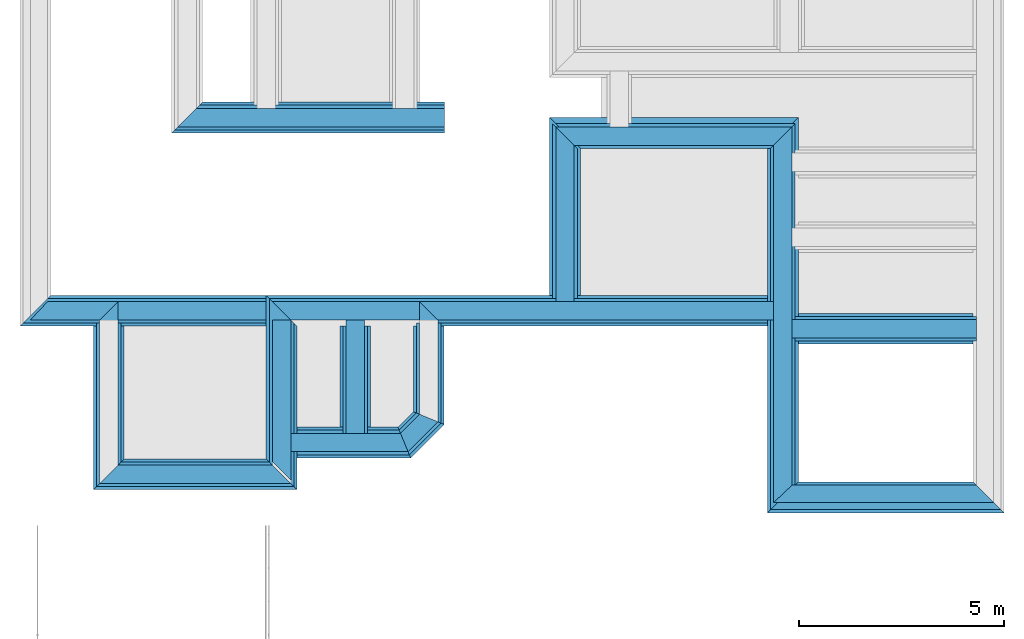
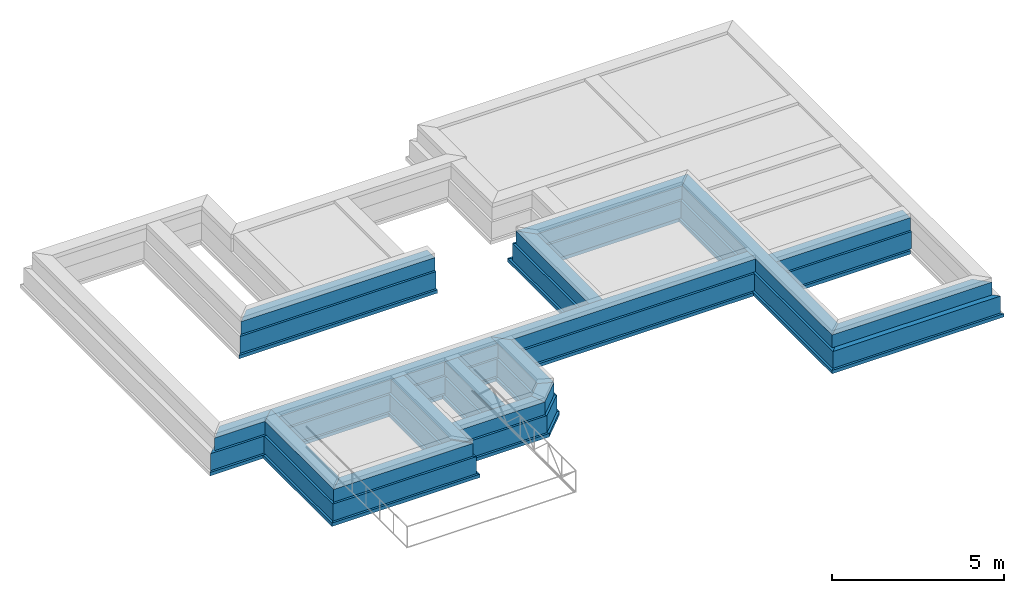
# One storey, part 5 of 7: 46 walls.
"""IFC4X3_ADD2 building model written with IfcOpenShell, lengths in metres."""

from ifc_helpers import new_model, entity, si_unit, converted_unit, frame, origin_with_axes, origin_2d_with_axis, place, context, subcontext, project, spatial, line, indexed_curve, outline, extrude, material, layer, layer_set, layer_usage, type_object, element, save


model = new_model("IFC4X3_ADD2")

# Units and contexts
model_context = context("Model", 3, precision=1e-05, world=origin_with_axes())
plan_context = context("Plan", 2, precision=1e-05, world=origin_2d_with_axis())
body_context = subcontext(model_context, "Body", "Model", "MODEL_VIEW")
ifc_project = project(units=[si_unit("VOLUMEUNIT", "CUBIC_METRE"), si_unit("LENGTHUNIT", "METRE"), converted_unit("PLANEANGLEUNIT", "degree", entity("IfcReal", 0.0174532925199433), si_unit("PLANEANGLEUNIT", "RADIAN"), dimensions=[0, 0, 0, 0, 0, 0, 0]), si_unit("AREAUNIT", "SQUARE_METRE")], contexts=[model_context, plan_context])

# Site, building, storey
site_placement = place(None, origin_with_axes())
site = spatial("IfcSite", under=ifc_project, at=site_placement)
building_placement = place(site_placement, origin_with_axes())
building = spatial("IfcBuilding", under=site, at=building_placement, Name="Building")
storey_placement = place(building_placement, frame((0.0, 0.0, -0.870000004768372), z_axis=(0.0, 0.0, 1.0), x_axis=(1.0, 0.0, 0.0)))
storey = spatial("IfcBuildingStorey", under=building, at=storey_placement, Name="Footing")

# Walls
ifc_material_1 = material(Name="Stone", Category="Structure")
ifc_layer_1 = layer(ifc_material_1, 0.449999988079071)
ifc_layer_set_1 = layer_set([ifc_layer_1])
ifc_layer_usage_1 = layer_usage(ifc_layer_set_1, "AXIS2", "POSITIVE", 0.0)
wall_type_1 = type_object("IfcWallType", Name="RRB_0.45W", PredefinedType="SHEAR", material=ifc_layer_set_1)
wall_1_placement = place(storey_placement, frame((23.7750164771225, 15.3793488442897, 0.719999998807908), z_axis=(0.0, 0.0, 1.0), x_axis=(0.999999999999822, -5.960464477538e-07, 0.0)))
element("IfcWall", 1, at=wall_1_placement, inside=storey, type_object=wall_type_1, material=ifc_layer_usage_1, Name="Wall", context=body_context, shape_type="SweptSolid", body=[
    extrude(outline(indexed_curve([(0.0, 0.0), (-9.81330211661044e-08, 0.449999988079071), (4.48665310620748, 0.449999988079071), (4.48665323122998, 0.0)], segments=[line(1, 2, 3, 4, 1)])), origin_with_axes(), (0.0, 0.0, 1.0), 0.449999988079071),
])
ifc_layer_usage_2 = layer_usage(ifc_layer_set_1, "AXIS2", "POSITIVE", 0.0)
wall_2_placement = place(storey_placement, frame((15.1466770042094, 13.3349130268063, 0.719999998807908), z_axis=(0.0, 0.0, 1.0), x_axis=(3.13916473260163e-07, 0.999999999999951, 0.0)))
element("IfcWall", 2, at=wall_2_placement, inside=storey, type_object=wall_type_1, material=ifc_layer_usage_2, Name="Wall", context=body_context, shape_type="SweptSolid", body=[
    extrude(outline(indexed_curve([(0.0, 0.0), (0.186396055761703, 0.449999988079071), (2.93110990416569, 0.449999988079071), (2.48110978576698, 0.0)], segments=[line(1, 2, 3, 4, 1)])), origin_with_axes(), (0.0, 0.0, 1.0), 0.449999988079071),
])
ifc_layer_usage_3 = layer_usage(ifc_layer_set_1, "AXIS2", "POSITIVE", 0.0)
wall_3_placement = place(storey_placement, frame((15.0466774778525, 15.8160228729249, 0.719999998807908), z_axis=(0.0, 0.0, 1.0), x_axis=(0.999999999999822, -5.960464477538e-07, 0.0)))
element("IfcWall", 3, at=wall_3_placement, inside=storey, type_object=wall_type_1, material=ifc_layer_usage_3, Name="Wall", context=body_context, shape_type="SweptSolid", body=[
    extrude(outline(indexed_curve([(0.0, 0.0), (-0.450000103371296, 0.449999988079071), (8.2783390779459, 0.449999988079071), (8.27833917616148, 0.0)], segments=[line(1, 2, 3, 4, 1)])), origin_with_axes(), (0.0, 0.0, 1.0), 0.449999988079071),
])
ifc_layer_usage_4 = layer_usage(ifc_layer_set_1, "AXIS2", "POSITIVE", 0.0)
wall_4_placement = place(storey_placement, frame((7.35359666377311, 12.2860256676357, 0.719999998807908), z_axis=(0.0, 0.0, 1.0), x_axis=(3.13916473260163e-07, 0.999999999999951, 0.0)))
element("IfcWall", 4, at=wall_4_placement, inside=storey, type_object=wall_type_1, material=ifc_layer_usage_4, Name="Wall", context=body_context, shape_type="SweptSolid", body=[
    extrude(outline(indexed_curve([(0.0, 0.0), (-0.449999961074437, 0.449999988079071), (3.52999582324251, 0.449999988079071), (3.97999606087995, 0.0)], segments=[line(1, 2, 3, 4, 1)])), origin_with_axes(), (0.0, 0.0, 1.0), 0.449999988079071),
])
ifc_layer_usage_5 = layer_usage(ifc_layer_set_1, "AXIS2", "POSITIVE", 0.0)
wall_5_placement = place(storey_placement, frame((23.7750149557985, 11.3693475723266, 0.719999998807908), z_axis=(0.0, 0.0, 1.0), x_axis=(3.13916473260163e-07, 0.999999999999951, 0.0)))
element("IfcWall", 5, at=wall_5_placement, inside=storey, type_object=wall_type_1, material=ifc_layer_usage_5, Name="Wall", context=body_context, shape_type="SweptSolid", body=[
    extrude(outline(indexed_curve([(0.42500000074508, 0.0), (1.47028964871403e-07, 0.449999988079071), (8.70354421117045, 0.449999988079071), (9.15354410546069, 0.0)], segments=[line(1, 2, 3, 4, 1)])), origin_with_axes(), (0.0, 0.0, 1.0), 0.449999988079071),
])
ifc_layer_usage_6 = layer_usage(ifc_layer_set_1, "AXIS2", "POSITIVE", 0.0)
wall_6_placement = place(storey_placement, frame((9.25813584427108, 20.5243873596191, 0.719999998807908), z_axis=(0.0, 0.0, 1.0), x_axis=(0.999999999999822, -5.960464477538e-07, 0.0)))
element("IfcWall", 6, at=wall_6_placement, inside=storey, type_object=wall_type_1, material=ifc_layer_usage_6, Name="Wall", context=body_context, shape_type="SweptSolid", body=[
    extrude(outline(indexed_curve([(-0.449999988079087, 0.0), (-1.22067763074548e-07, 0.449999988079071), (6.05208381845608, 0.449999988079071), (6.05208381845608, 0.0)], segments=[line(1, 2, 3, 4, 1)])), origin_with_axes(), (0.0, 0.0, 1.0), 0.449999988079071),
])
ifc_layer_usage_7 = layer_usage(ifc_layer_set_1, "AXIS2", "POSITIVE", 0.0)
wall_7_placement = place(storey_placement, frame((11.5629977944495, 12.3610239028931, 0.719999998807908), z_axis=(0.0, 0.0, 1.0), x_axis=(3.13916473260163e-07, 0.999999999999951, 0.0)))
element("IfcWall", 7, at=wall_7_placement, inside=storey, type_object=wall_type_1, material=ifc_layer_usage_7, Name="Wall", context=body_context, shape_type="SweptSolid", body=[
    extrude(outline(indexed_curve([(-0.449999988079072, 0.0), (2.68782058983727e-08, 0.449999988079071), (3.45499654674015, 0.449999988079071), (3.454996452804, 0.0)], segments=[line(1, 2, 3, 4, 1)])), origin_with_axes(), (0.0, 0.0, 1.0), 0.449999988079071),
])
ifc_layer_usage_8 = layer_usage(ifc_layer_set_1, "AXIS2", "POSITIVE", 0.0)
wall_8_placement = place(storey_placement, frame((14.4189835934303, 12.6072198349405, 0.719999998807908), z_axis=(0.0, 0.0, 1.0), x_axis=(0.707106840791191, 0.707106721581899, 0.0)))
element("IfcWall", 8, at=wall_8_placement, inside=storey, type_object=wall_type_1, material=ifc_layer_usage_8, Name="Wall", context=body_context, shape_type="SweptSolid", body=[
    extrude(outline(indexed_curve([(0.0, 0.0), (0.186396239135942, 0.449999988079071), (0.842717773351463, 0.449999988079071), (1.02911380402565, 0.0)], segments=[line(1, 2, 3, 4, 1)])), origin_with_axes(), (0.0, 0.0, 1.0), 0.449999988079071),
])
ifc_layer_usage_9 = layer_usage(ifc_layer_set_1, "AXIS2", "POSITIVE", 0.0)
wall_9_placement = place(storey_placement, frame((13.3589563840624, 12.6072204919225, 0.719999998807908), z_axis=(0.0, 0.0, 1.0), x_axis=(3.13916473260163e-07, 0.999999999999951, 0.0)))
element("IfcWall", 9, at=wall_9_placement, inside=storey, type_object=wall_type_1, material=ifc_layer_usage_9, Name="Wall", context=body_context, shape_type="SweptSolid", body=[
    extrude(outline(indexed_curve([(0.449999988079092, 0.0), (0.450000125309711, 0.449999988079071), (3.20880352988753, 0.449999988079071), (3.20880339956792, 0.0)], segments=[line(1, 2, 3, 4, 1)])), origin_with_axes(), (0.0, 0.0, 1.0), 0.449999988079071),
])
ifc_layer_usage_10 = layer_usage(ifc_layer_set_1, "AXIS2", "POSITIVE", 0.0)
wall_10_placement = place(storey_placement, frame((15.1466780013493, 16.2660184840428, 0.719999998807908), z_axis=(0.0, 0.0, 1.0), x_axis=(-0.999999999999924, 3.89414367418765e-07, 0.0)))
element("IfcWall", 10, at=wall_10_placement, inside=storey, type_object=wall_type_1, material=ifc_layer_usage_10, Name="Wall", context=body_context, shape_type="SweptSolid", body=[
    extrude(outline(indexed_curve([(0.449999988079071, 0.0), (0.449999965929192, 0.449999988079071), (7.79307999653564, 0.449999988079071), (7.79308002299699, 0.0)], segments=[line(1, 2, 3, 4, 1)])), origin_with_axes(), (0.0, 0.0, 1.0), 0.449999988079071),
])
ifc_layer_usage_11 = layer_usage(ifc_layer_set_1, "AXIS2", "POSITIVE", 0.0)
wall_11_placement = place(storey_placement, frame((11.5629977696537, 12.2860240936279, 0.719999998807908), z_axis=(0.0, 0.0, 1.0), x_axis=(-0.999999999999924, 3.89414367418765e-07, 0.0)))
element("IfcWall", 11, at=wall_11_placement, inside=storey, type_object=wall_type_1, material=ifc_layer_usage_11, Name="Wall", context=body_context, shape_type="SweptSolid", body=[
    extrude(outline(indexed_curve([(0.449999988079072, 0.0), (-2.6461350745525e-08, 0.449999988079071), (4.65940106875073, 0.449999988079071), (4.20940110713301, 0.0)], segments=[line(1, 2, 3, 4, 1)])), origin_with_axes(), (0.0, 0.0, 1.0), 0.449999988079071),
])
ifc_layer_usage_12 = layer_usage(ifc_layer_set_1, "AXIS2", "POSITIVE", 0.0)
wall_12_placement = place(storey_placement, frame((18.466680573821, 15.8160208088996, 0.719999998807908), z_axis=(0.0, 0.0, 1.0), x_axis=(3.13916473260163e-07, 0.999999999999951, 0.0)))
element("IfcWall", 12, at=wall_12_placement, inside=storey, type_object=wall_type_1, material=ifc_layer_usage_12, Name="Wall", context=body_context, shape_type="SweptSolid", body=[
    extrude(outline(indexed_curve([(0.44999998807909, 0.0), (0.450000118398703, 0.449999988079071), (4.70687373541192, 0.449999988079071), (4.256873653544, 0.0)], segments=[line(1, 2, 3, 4, 1)])), origin_with_axes(), (0.0, 0.0, 1.0), 0.449999988079071),
])
ifc_layer_usage_13 = layer_usage(ifc_layer_set_1, "AXIS2", "POSITIVE", 0.0)
wall_13_placement = place(storey_placement, frame((11.5629978758452, 12.6072216033935, 0.719999998807908), z_axis=(0.0, 0.0, 1.0), x_axis=(0.999999999999822, -5.960464477538e-07, 0.0)))
element("IfcWall", 13, at=wall_13_placement, inside=storey, type_object=wall_type_1, material=ifc_layer_usage_13, Name="Wall", context=body_context, shape_type="SweptSolid", body=[
    extrude(outline(indexed_curve([(0.0, 0.0), (-1.19445784433059e-07, 0.449999988079071), (2.66958956740739, 0.449999988079071), (2.85598578373842, 0.0)], segments=[line(1, 2, 3, 4, 1)])), origin_with_axes(), (0.0, 0.0, 1.0), 0.449999988079071),
])
ifc_layer_usage_14 = layer_usage(ifc_layer_set_1, "AXIS2", "POSITIVE", 0.0)
wall_14_placement = place(storey_placement, frame((7.35359797835293, 16.2660217285155, 0.719999998807908), z_axis=(0.0, 0.0, 1.0), x_axis=(-0.999999999999924, 3.89414367418765e-07, 0.0)))
element("IfcWall", 14, at=wall_14_placement, inside=storey, type_object=wall_type_1, material=ifc_layer_usage_14, Name="Wall", context=body_context, shape_type="SweptSolid", body=[
    extrude(outline(indexed_curve([(0.0, 0.0), (0.449999961617721, 0.449999988079071), (2.13955890890689, 0.449999988079071), (1.714558939226, 0.0)], segments=[line(1, 2, 3, 4, 1)])), origin_with_axes(), (0.0, 0.0, 1.0), 0.449999988079071),
])
ifc_layer_usage_15 = layer_usage(ifc_layer_set_1, "AXIS2", "POSITIVE", 0.0)
wall_15_placement = place(storey_placement, frame((18.4666819764865, 20.0728944624433, 0.719999998807908), z_axis=(0.0, 0.0, 1.0), x_axis=(0.999999999999822, -5.960464477538e-07, 0.0)))
element("IfcWall", 15, at=wall_15_placement, inside=storey, type_object=wall_type_1, material=ifc_layer_usage_15, Name="Wall", context=body_context, shape_type="SweptSolid", body=[
    extrude(outline(indexed_curve([(0.0, 0.0), (-0.450000108145878, 0.449999988079071), (5.30833617205419, 0.449999988079071), (4.85833628210813, 0.0)], segments=[line(1, 2, 3, 4, 1)])), origin_with_axes(), (0.0, 0.0, 1.0), 0.449999988079071),
])
ifc_material_2 = material(Name="Plaster", Category="Finishes")
ifc_layer_2 = layer(ifc_material_2, 0.00999999977648258)
ifc_layer_3 = layer(ifc_material_1, 0.405000001192093)
ifc_layer_4 = layer(ifc_material_2, 0.00999999977648258)
ifc_layer_set_2 = layer_set([ifc_layer_2, ifc_layer_3, ifc_layer_4])
ifc_layer_usage_16 = layer_usage(ifc_layer_set_2, "AXIS2", "POSITIVE", 0.0)
wall_type_2 = type_object("IfcWallType", Name="RRB_0.425W", PredefinedType="SHEAR", material=ifc_layer_set_2)
wall_16_placement = place(storey_placement, frame((23.7750149621858, 11.3693475723266, 0.719999998807908), z_axis=(0.0, 0.0, 1.0), x_axis=(0.999999999999822, -5.960464477538e-07, 0.0)))
element("IfcWall", 16, at=wall_16_placement, inside=storey, type_object=wall_type_2, material=ifc_layer_usage_16, Name="Wall", context=body_context, shape_type="SweptSolid", body=[
    extrude(outline(indexed_curve([(-0.449999988079081, 0.0), (-9.26811892745667e-08, 0.425000000745058), (4.48665335278053, 0.425000000745058), (4.91165347159026, 0.0)], segments=[line(1, 2, 3, 4, 1)])), origin_with_axes(), (0.0, 0.0, 1.0), 0.449999988079071),
])
ifc_material_3 = material(Name="Wall")
ifc_layer_5 = layer(ifc_material_3, 0.600000023841858, Name="concrete")
ifc_layer_set_3 = layer_set([ifc_layer_5], Name="concrete")
ifc_layer_usage_17 = layer_usage(ifc_layer_set_3, "AXIS2", "POSITIVE", 0.0)
wall_type_3 = type_object("IfcWallType", Name="RRB_0.6W", PredefinedType="SHEAR", material=ifc_layer_set_3)
wall_17_placement = place(storey_placement, frame((14.4500515221254, 12.5322200975236, 0.120000004768372), z_axis=(0.0, 0.0, 1.0), x_axis=(0.707106840791191, 0.707106721581899, 0.0)))
element("IfcWall", 17, at=wall_17_placement, inside=storey, type_object=wall_type_3, material=ifc_layer_usage_17, Name="Wall", context=body_context, shape_type="SweptSolid", body=[
    extrude(outline(indexed_curve([(0.0, 0.0), (0.248528335537855, 0.600000023841858), (0.842714835397712, 0.600000023841858), (1.09124289229101, 0.0)], segments=[line(1, 2, 3, 4, 1)])), origin_with_axes(), (0.0, 0.0, 1.0), 0.600000023841858),
])
ifc_layer_usage_18 = layer_usage(ifc_layer_set_3, "AXIS2", "POSITIVE", 0.0)
wall_18_placement = place(storey_placement, frame((11.6379976037146, 12.3610239320991, 0.120000004768372), z_axis=(0.0, 0.0, 1.0), x_axis=(-0.999999999999924, 3.89414367418765e-07, 0.0)))
element("IfcWall", 18, at=wall_18_placement, inside=storey, type_object=wall_type_3, material=ifc_layer_usage_18, Name="Wall", context=body_context, shape_type="SweptSolid", body=[
    extrude(outline(indexed_curve([(0.600000023841859, 0.0), (-3.37259327238358e-08, 0.600000023841858), (4.80940064221081, 0.600000023841858), (4.20940065383951, 0.0)], segments=[line(1, 2, 3, 4, 1)])), origin_with_axes(), (0.0, 0.0, 1.0), 0.600000023841858),
])
ifc_layer_usage_19 = layer_usage(ifc_layer_set_3, "AXIS2", "POSITIVE", 0.0)
wall_19_placement = place(storey_placement, frame((18.5416794058681, 15.7410208639421, 0.120000004768372), z_axis=(0.0, 0.0, 1.0), x_axis=(3.13916473260163e-07, 0.999999999999951, 0.0)))
element("IfcWall", 19, at=wall_19_placement, inside=storey, type_object=wall_type_3, material=ifc_layer_usage_19, Name="Wall", context=body_context, shape_type="SweptSolid", body=[
    extrude(outline(indexed_curve([(0.600000023841883, 0.0), (0.600000196322957, 0.600000023841858), (4.85687366928037, 0.600000023841858), (4.25687346879169, 0.0)], segments=[line(1, 2, 3, 4, 1)])), origin_with_axes(), (0.0, 0.0, 1.0), 0.600000023841858),
])
ifc_layer_usage_20 = layer_usage(ifc_layer_set_3, "AXIS2", "POSITIVE", 0.0)
wall_20_placement = place(storey_placement, frame((23.8500150770871, 15.3043489903219, 0.120000004768372), z_axis=(0.0, 0.0, 1.0), x_axis=(0.999999999999822, -5.960464477538e-07, 0.0)))
element("IfcWall", 20, at=wall_20_placement, inside=storey, type_object=wall_type_3, material=ifc_layer_usage_20, Name="Wall", context=body_context, shape_type="SweptSolid", body=[
    extrude(outline(indexed_curve([(0.0, 0.0), (-1.64834769827048e-07, 0.600000023841858), (4.41165560377788, 0.600000023841858), (4.41165577052876, 0.0)], segments=[line(1, 2, 3, 4, 1)])), origin_with_axes(), (0.0, 0.0, 1.0), 0.600000023841858),
])
ifc_layer_usage_21 = layer_usage(ifc_layer_set_3, "AXIS2", "POSITIVE", 0.0)
wall_21_placement = place(storey_placement, frame((13.4339570999146, 12.457221031189, 0.120000004768372), z_axis=(0.0, 0.0, 1.0), x_axis=(3.13916473260163e-07, 0.999999999999951, 0.0)))
element("IfcWall", 21, at=wall_21_placement, inside=storey, type_object=wall_type_3, material=ifc_layer_usage_21, Name="Wall", context=body_context, shape_type="SweptSolid", body=[
    extrude(outline(indexed_curve([(0.600000023841886, 0.0), (0.600000207250802, 0.600000023841858), (3.20880245678658, 0.600000023841858), (3.20880245678658, 0.0)], segments=[line(1, 2, 3, 4, 1)])), origin_with_axes(), (0.0, 0.0, 1.0), 0.600000023841858),
])
ifc_layer_usage_22 = layer_usage(ifc_layer_set_3, "AXIS2", "POSITIVE", 0.0)
wall_22_placement = place(storey_placement, frame((11.6379987314599, 15.7410250157116, 0.120000004768372), z_axis=(0.0, 0.0, 1.0), x_axis=(0.999999999999822, -5.960464477538e-07, 0.0)))
element("IfcWall", 22, at=wall_22_placement, inside=storey, type_object=wall_type_3, material=ifc_layer_usage_22, Name="Wall", context=body_context, shape_type="SweptSolid", body=[
    extrude(outline(indexed_curve([(0.0, 0.0), (-0.600000181284445, 0.600000023841858), (11.6120162987777, 0.600000023841858), (11.6120164636125, 0.0)], segments=[line(1, 2, 3, 4, 1)])), origin_with_axes(), (0.0, 0.0, 1.0), 0.600000023841858),
])
ifc_layer_usage_23 = layer_usage(ifc_layer_set_3, "AXIS2", "POSITIVE", 0.0)
wall_23_placement = place(storey_placement, frame((11.6379989301293, 16.3410187059637, 0.120000004768372), z_axis=(0.0, 0.0, 1.0), x_axis=(-0.999999999999924, 3.89414367418765e-07, 0.0)))
element("IfcWall", 23, at=wall_23_placement, inside=storey, type_object=wall_type_3, material=ifc_layer_usage_23, Name="Wall", context=body_context, shape_type="SweptSolid", body=[
    extrude(outline(indexed_curve([(0.600000023841859, 0.0), (0.599999990115926, 0.600000023841858), (6.59895989615596, 0.600000023841858), (5.9989599137992, 0.0)], segments=[line(1, 2, 3, 4, 1)])), origin_with_axes(), (0.0, 0.0, 1.0), 0.600000023841858),
])
ifc_layer_usage_24 = layer_usage(ifc_layer_set_3, "AXIS2", "POSITIVE", 0.0)
wall_24_placement = place(storey_placement, frame((7.42859694987542, 12.3610255061067, 0.120000004768372), z_axis=(0.0, 0.0, 1.0), x_axis=(3.13916473260163e-07, 0.999999999999951, 0.0)))
element("IfcWall", 24, at=wall_24_placement, inside=storey, type_object=wall_type_3, material=ifc_layer_usage_24, Name="Wall", context=body_context, shape_type="SweptSolid", body=[
    extrude(outline(indexed_curve([(0.0, 0.0), (-0.599999987835678, 0.600000023841858), (3.3799948082492, 0.600000023841858), (3.37999476947094, 0.0)], segments=[line(1, 2, 3, 4, 1)])), origin_with_axes(), (0.0, 0.0, 1.0), 0.600000023841858),
])
ifc_layer_usage_25 = layer_usage(ifc_layer_set_3, "AXIS2", "POSITIVE", 0.0)
wall_25_placement = place(storey_placement, frame((9.33313562918742, 20.4493865966797, 0.120000004768372), z_axis=(0.0, 0.0, 1.0), x_axis=(0.999999999999822, -5.960464477538e-07, 0.0)))
element("IfcWall", 25, at=wall_25_placement, inside=storey, type_object=wall_type_3, material=ifc_layer_usage_25, Name="Wall", context=body_context, shape_type="SweptSolid", body=[
    extrude(outline(indexed_curve([(-0.60000002384188, 0.0), (-1.62916114084486e-07, 0.600000023841858), (5.97708403273492, 0.600000023841858), (5.97708403273492, 0.0)], segments=[line(1, 2, 3, 4, 1)])), origin_with_axes(), (0.0, 0.0, 1.0), 0.600000023841858),
])
ifc_layer_usage_26 = layer_usage(ifc_layer_set_3, "AXIS2", "POSITIVE", 0.0)
wall_26_placement = place(storey_placement, frame((11.7129974686632, 12.5322217941284, 0.120000004768372), z_axis=(0.0, 0.0, 1.0), x_axis=(0.999999999999822, -5.960464477538e-07, 0.0)))
element("IfcWall", 26, at=wall_26_placement, inside=storey, type_object=wall_type_3, material=ifc_layer_usage_26, Name="Wall", context=body_context, shape_type="SweptSolid", body=[
    extrude(outline(indexed_curve([(0.0, 0.0), (-1.57167747032798e-07, 0.600000023841858), (2.48852581879504, 0.600000023841858), (2.73705412682357, 0.0)], segments=[line(1, 2, 3, 4, 1)])), origin_with_axes(), (0.0, 0.0, 1.0), 0.600000023841858),
])
ifc_layer_usage_27 = layer_usage(ifc_layer_set_3, "AXIS2", "POSITIVE", 0.0)
wall_27_placement = place(storey_placement, frame((23.8500137564538, 11.1943474262957, 0.120000004768372), z_axis=(0.0, 0.0, 1.0), x_axis=(3.13916473260163e-07, 0.999999999999951, 0.0)))
element("IfcWall", 27, at=wall_27_placement, inside=storey, type_object=wall_type_3, material=ifc_layer_usage_27, Name="Wall", context=body_context, shape_type="SweptSolid", body=[
    extrude(outline(indexed_curve([(0.600000023841889, 0.0), (1.9550465227668e-07, 0.600000023841858), (8.8035438529559, 0.600000023841858), (9.40354370015098, 0.0)], segments=[line(1, 2, 3, 4, 1)])), origin_with_axes(), (0.0, 0.0, 1.0), 0.600000023841858),
])
ifc_layer_usage_28 = layer_usage(ifc_layer_set_3, "AXIS2", "POSITIVE", 0.0)
wall_28_placement = place(storey_placement, frame((18.5416808073643, 19.9978943318125, 0.120000004768372), z_axis=(0.0, 0.0, 1.0), x_axis=(0.999999999999822, -5.960464477538e-07, 0.0)))
element("IfcWall", 28, at=wall_28_placement, inside=storey, type_object=wall_type_3, material=ifc_layer_usage_28, Name="Wall", context=body_context, shape_type="SweptSolid", body=[
    extrude(outline(indexed_curve([(0.0, 0.0), (-0.600000183930945, 0.600000023841858), (5.30833561302661, 0.600000023841858), (4.7083357540195, 0.0)], segments=[line(1, 2, 3, 4, 1)])), origin_with_axes(), (0.0, 0.0, 1.0), 0.600000023841858),
])
ifc_layer_usage_29 = layer_usage(ifc_layer_set_3, "AXIS2", "POSITIVE", 0.0)
wall_29_placement = place(storey_placement, frame((15.2216768362291, 13.3038451893435, 0.120000004768372), z_axis=(0.0, 0.0, 1.0), x_axis=(3.13916473260163e-07, 0.999999999999951, 0.0)))
element("IfcWall", 29, at=wall_29_placement, inside=storey, type_object=wall_type_3, material=ifc_layer_usage_29, Name="Wall", context=body_context, shape_type="SweptSolid", body=[
    extrude(outline(indexed_curve([(0.0, 0.0), (0.248528087591311, 0.600000023841858), (2.43717784407926, 0.600000023841858), (2.43717767159818, 0.0)], segments=[line(1, 2, 3, 4, 1)])), origin_with_axes(), (0.0, 0.0, 1.0), 0.600000023841858),
])
ifc_layer_usage_30 = layer_usage(ifc_layer_set_3, "AXIS2", "POSITIVE", 0.0)
wall_30_placement = place(storey_placement, frame((23.8500137570046, 11.1943474262957, 0.120000004768372), z_axis=(0.0, 0.0, 1.0), x_axis=(0.999999999999822, -5.960464477538e-07, 0.0)))
element("IfcWall", 30, at=wall_30_placement, inside=storey, type_object=wall_type_3, material=ifc_layer_usage_30, Name="Wall", context=body_context, shape_type="SweptSolid", body=[
    extrude(outline(indexed_curve([(-0.600000023841881, 0.0), (-1.64834769827047e-07, 0.600000023841858), (4.41165561690321, 0.600000023841858), (5.01165580749597, 0.0)], segments=[line(1, 2, 3, 4, 1)])), origin_with_axes(), (0.0, 0.0, 1.0), 0.600000023841858),
])
ifc_layer_usage_31 = layer_usage(ifc_layer_set_3, "AXIS2", "POSITIVE", 0.0)
wall_31_placement = place(storey_placement, frame((11.6379976037146, 12.3610239309375, 0.120000004768372), z_axis=(0.0, 0.0, 1.0), x_axis=(3.13916473260163e-07, 0.999999999999951, 0.0)))
element("IfcWall", 31, at=wall_31_placement, inside=storey, type_object=wall_type_3, material=ifc_layer_usage_31, Name="Wall", context=body_context, shape_type="SweptSolid", body=[
    extrude(outline(indexed_curve([(-0.600000023841859, 0.0), (3.60061807869183e-08, 0.600000023841858), (3.98000128109723, 0.600000023841858), (3.38000108477427, 0.0)], segments=[line(1, 2, 3, 4, 1)])), origin_with_axes(), (0.0, 0.0, 1.0), 0.600000023841858),
])
ifc_layer_6 = layer(ifc_material_3, 0.75)
ifc_layer_set_4 = layer_set([ifc_layer_6])
ifc_layer_usage_32 = layer_usage(ifc_layer_set_4, "AXIS2", "POSITIVE", 0.0)
wall_type_4 = type_object("IfcWallType", PredefinedType="SHEAR", material=ifc_layer_set_4)
wall_32_placement = place(storey_placement, frame((11.712997086914, 12.4360237607739, 0.0), z_axis=(0.0, 0.0, 1.0), x_axis=(-0.999999999999924, 3.89414367418765e-07, 0.0)))
element("IfcWall", 32, at=wall_32_placement, inside=storey, type_object=wall_type_4, material=ifc_layer_usage_32, Name="Wall", context=body_context, shape_type="SweptSolid", body=[
    extrude(outline(indexed_curve([(0.75, 0.0), (-3.451784469366e-08, 0.75), (4.95940036665373, 0.75), (4.20940041099193, 0.0)], segments=[line(1, 2, 3, 4, 1)])), origin_with_axes(), (0.0, 0.0, 1.0), 0.119999997317791),
])
ifc_layer_usage_33 = layer_usage(ifc_layer_set_4, "AXIS2", "POSITIVE", 0.0)
wall_33_placement = place(storey_placement, frame((7.50359667592235, 12.4360253347814, 0.0), z_axis=(0.0, 0.0, 1.0), x_axis=(3.13916473260163e-07, 0.999999999999951, 0.0)))
element("IfcWall", 33, at=wall_33_placement, inside=storey, type_object=wall_type_4, material=ifc_layer_usage_33, Name="Wall", context=body_context, shape_type="SweptSolid", body=[
    extrude(outline(indexed_curve([(0.0, 0.0), (-0.7499999546577, 0.75), (3.22999572040198, 0.75), (3.22999567211225, 0.0)], segments=[line(1, 2, 3, 4, 1)])), origin_with_axes(), (0.0, 0.0, 1.0), 0.119999997317791),
])
ifc_layer_usage_34 = layer_usage(ifc_layer_set_4, "AXIS2", "POSITIVE", 0.0)
wall_34_placement = place(storey_placement, frame((11.712998453607, 16.4160194137244, 0.0), z_axis=(0.0, 0.0, 1.0), x_axis=(-0.999999999999924, 3.89414367418765e-07, 0.0)))
element("IfcWall", 34, at=wall_34_placement, inside=storey, type_object=wall_type_4, material=ifc_layer_usage_34, Name="Wall", context=body_context, shape_type="SweptSolid", body=[
    extrude(outline(indexed_curve([(0.750000000000001, 0.0), (0.749999958514383, 0.75), (6.74895961318927, 0.75), (5.99895966504564, 0.0)], segments=[line(1, 2, 3, 4, 1)])), origin_with_axes(), (0.0, 0.0, 1.0), 0.119999997317791),
])
ifc_layer_usage_35 = layer_usage(ifc_layer_set_4, "AXIS2", "POSITIVE", 0.0)
wall_35_placement = place(storey_placement, frame((11.7129971169219, 12.4360237607738, 0.0), z_axis=(0.0, 0.0, 1.0), x_axis=(3.13916473260163e-07, 0.999999999999951, 0.0)))
element("IfcWall", 35, at=wall_35_placement, inside=storey, type_object=wall_type_4, material=ifc_layer_usage_35, Name="Wall", context=body_context, shape_type="SweptSolid", body=[
    extrude(outline(indexed_curve([(-0.750000000000001, 0.0), (4.50077241979968e-08, 0.75), (3.98000111844521, 0.75), (3.23000090214441, 0.0)], segments=[line(1, 2, 3, 4, 1)])), origin_with_axes(), (0.0, 0.0, 1.0), 0.119999997317791),
])
ifc_layer_usage_36 = layer_usage(ifc_layer_set_4, "AXIS2", "POSITIVE", 0.0)
wall_36_placement = place(storey_placement, frame((13.5089565232207, 12.4572212834925, 0.0), z_axis=(0.0, 0.0, 1.0), x_axis=(3.13916473260163e-07, 0.999999999999951, 0.0)))
element("IfcWall", 36, at=wall_36_placement, inside=storey, type_object=wall_type_4, material=ifc_layer_usage_36, Name="Wall", context=body_context, shape_type="SweptSolid", body=[
    extrude(outline(indexed_curve([(0.750000000000037, 0.0), (0.75000023498831, 0.75), (3.20880251398879, 0.75), (3.20880229768802, 0.0)], segments=[line(1, 2, 3, 4, 1)])), origin_with_axes(), (0.0, 0.0, 1.0), 0.119999997317791),
])
ifc_layer_usage_37 = layer_usage(ifc_layer_set_4, "AXIS2", "POSITIVE", 0.0)
wall_37_placement = place(storey_placement, frame((15.2966765831064, 13.2727789912786, 0.0), z_axis=(0.0, 0.0, 1.0), x_axis=(3.13916473260163e-07, 0.999999999999951, 0.0)))
element("IfcWall", 37, at=wall_37_placement, inside=storey, type_object=wall_type_4, material=ifc_layer_usage_37, Name="Wall", context=body_context, shape_type="SweptSolid", body=[
    extrude(outline(indexed_curve([(0.0, 0.0), (0.310660159435322, 0.75), (2.39324353560032, 0.75), (2.39324353560032, 0.0)], segments=[line(1, 2, 3, 4, 1)])), origin_with_axes(), (0.0, 0.0, 1.0), 0.119999997317791),
])
ifc_layer_usage_38 = layer_usage(ifc_layer_set_4, "AXIS2", "POSITIVE", 0.0)
wall_38_placement = place(storey_placement, frame((11.7129971240043, 12.4572223888417, 0.0), z_axis=(0.0, 0.0, 1.0), x_axis=(0.999999999999822, -5.960464477538e-07, 0.0)))
element("IfcWall", 38, at=wall_38_placement, inside=storey, type_object=wall_type_4, material=ifc_layer_usage_38, Name="Wall", context=body_context, shape_type="SweptSolid", body=[
    extrude(outline(indexed_curve([(0.0, 0.0), (-1.96459677970218e-07, 0.75), (2.45746044805216, 0.75), (2.76812074576488, 0.0)], segments=[line(1, 2, 3, 4, 1)])), origin_with_axes(), (0.0, 0.0, 1.0), 0.119999997317791),
])
ifc_layer_usage_39 = layer_usage(ifc_layer_set_4, "AXIS2", "POSITIVE", 0.0)
wall_39_placement = place(storey_placement, frame((9.40813504085922, 20.3743879886661, 0.0), z_axis=(0.0, 0.0, 1.0), x_axis=(0.999999999999822, -5.960464477538e-07, 0.0)))
element("IfcWall", 39, at=wall_39_placement, inside=storey, type_object=wall_type_4, material=ifc_layer_usage_39, Name="Wall", context=body_context, shape_type="SweptSolid", body=[
    extrude(outline(indexed_curve([(-0.750000000000028, 0.0), (-2.03834519745982e-07, 0.75), (5.90208424701316, 0.75), (5.90208424701316, 0.0)], segments=[line(1, 2, 3, 4, 1)])), origin_with_axes(), (0.0, 0.0, 1.0), 0.119999997317791),
])
ifc_layer_usage_40 = layer_usage(ifc_layer_set_4, "AXIS2", "POSITIVE", 0.0)
wall_40_placement = place(storey_placement, frame((18.6166796713225, 15.6660205047099, 0.0), z_axis=(0.0, 0.0, 1.0), x_axis=(3.13916473260163e-07, 0.999999999999951, 0.0)))
element("IfcWall", 40, at=wall_40_placement, inside=storey, type_object=wall_type_4, material=ifc_layer_usage_40, Name="Wall", context=body_context, shape_type="SweptSolid", body=[
    extrude(outline(indexed_curve([(0.750000000000031, 0.0), (0.750000216300797, 0.75), (5.08187320895466, 0.75), (4.33187298335619, 0.0)], segments=[line(1, 2, 3, 4, 1)])), origin_with_axes(), (0.0, 0.0, 1.0), 0.119999997317791),
])
ifc_layer_usage_41 = layer_usage(ifc_layer_set_4, "AXIS2", "POSITIVE", 0.0)
wall_41_placement = place(storey_placement, frame((23.9250144574532, 11.1193472715932, 0.0), z_axis=(0.0, 0.0, 1.0), x_axis=(3.13916473260163e-07, 0.999999999999951, 0.0)))
element("IfcWall", 41, at=wall_41_placement, inside=storey, type_object=wall_type_4, material=ifc_layer_usage_41, Name="Wall", context=body_context, shape_type="SweptSolid", body=[
    extrude(outline(indexed_curve([(0.750000000000039, 0.0), (2.44380802087435e-07, 0.75), (8.87854320807323, 0.75), (9.62854298726477, 0.0)], segments=[line(1, 2, 3, 4, 1)])), origin_with_axes(), (0.0, 0.0, 1.0), 0.119999997317791),
])
ifc_layer_usage_42 = layer_usage(ifc_layer_set_4, "AXIS2", "POSITIVE", 0.0)
wall_42_placement = place(storey_placement, frame((11.7129981960658, 15.6660246629181, 0.0), z_axis=(0.0, 0.0, 1.0), x_axis=(0.999999999999822, -5.960464477538e-07, 0.0)))
element("IfcWall", 42, at=wall_42_placement, inside=storey, type_object=wall_type_4, material=ifc_layer_usage_42, Name="Wall", context=body_context, shape_type="SweptSolid", body=[
    extrude(outline(indexed_curve([(0.0, 0.0), (-0.750000196459704, 0.75), (11.4620175211609, 0.75), (11.4620177265147, 0.0)], segments=[line(1, 2, 3, 4, 1)])), origin_with_axes(), (0.0, 0.0, 1.0), 0.119999997317791),
])
ifc_layer_usage_43 = layer_usage(ifc_layer_set_4, "AXIS2", "POSITIVE", 0.0)
wall_43_placement = place(storey_placement, frame((23.9250144574532, 11.1193472715932, 0.0), z_axis=(0.0, 0.0, 1.0), x_axis=(0.999999999999822, -5.960464477538e-07, 0.0)))
element("IfcWall", 43, at=wall_43_placement, inside=storey, type_object=wall_type_4, material=ifc_layer_usage_43, Name="Wall", context=body_context, shape_type="SweptSolid", body=[
    extrude(outline(indexed_curve([(-0.750000000000028, 0.0), (-2.06090370372681e-07, 0.75), (4.2616561413704, 0.75), (5.01165634982424, 0.0)], segments=[line(1, 2, 3, 4, 1)])), origin_with_axes(), (0.0, 0.0, 1.0), 0.119999997317791),
])
ifc_layer_usage_44 = layer_usage(ifc_layer_set_4, "AXIS2", "POSITIVE", 0.0)
wall_44_placement = place(storey_placement, frame((23.9250157778293, 15.2293487665903, 0.0), z_axis=(0.0, 0.0, 1.0), x_axis=(0.999999999999822, -5.960464477538e-07, 0.0)))
element("IfcWall", 44, at=wall_44_placement, inside=storey, type_object=wall_type_4, material=ifc_layer_usage_44, Name="Wall", context=body_context, shape_type="SweptSolid", body=[
    extrude(outline(indexed_curve([(0.0, 0.0), (-2.06090370372681e-07, 0.75), (4.26165612841869, 0.75), (4.26165633687251, 0.0)], segments=[line(1, 2, 3, 4, 1)])), origin_with_axes(), (0.0, 0.0, 1.0), 0.119999997317791),
])
ifc_layer_usage_45 = layer_usage(ifc_layer_set_4, "AXIS2", "POSITIVE", 0.0)
wall_45_placement = place(storey_placement, frame((18.6166810963623, 19.9978934880659, 0.0), z_axis=(0.0, 0.0, 1.0), x_axis=(0.999999999999822, -5.960464477538e-07, 0.0)))
element("IfcWall", 45, at=wall_45_placement, inside=storey, type_object=wall_type_4, material=ifc_layer_usage_45, Name="Wall", context=body_context, shape_type="SweptSolid", body=[
    extrude(outline(indexed_curve([(0.0, 0.0), (-0.750000200310215, 0.75), (5.30833600731585, 0.75), (4.55833621340619, 0.0)], segments=[line(1, 2, 3, 4, 1)])), origin_with_axes(), (0.0, 0.0, 1.0), 0.119999997317791),
])
ifc_layer_usage_46 = layer_usage(ifc_layer_set_4, "AXIS2", "POSITIVE", 0.0)
wall_46_placement = place(storey_placement, frame((14.4811177863082, 12.4572206554527, 0.0), z_axis=(0.0, 0.0, 1.0), x_axis=(0.707106960000462, 0.707106602372588, 0.0)))
element("IfcWall", 46, at=wall_46_placement, inside=storey, type_object=wall_type_4, material=ifc_layer_usage_46, Name="Wall", context=body_context, shape_type="SweptSolid", body=[
    extrude(outline(indexed_curve([(0.0, 0.0), (0.310660340087305, 0.75), (0.842713886681536, 0.75), (1.15337401967819, 0.0)], segments=[line(1, 2, 3, 4, 1)])), origin_with_axes(), (0.0, 0.0, 1.0), 0.119999997317791),
])

save(model, "model.ifc")
